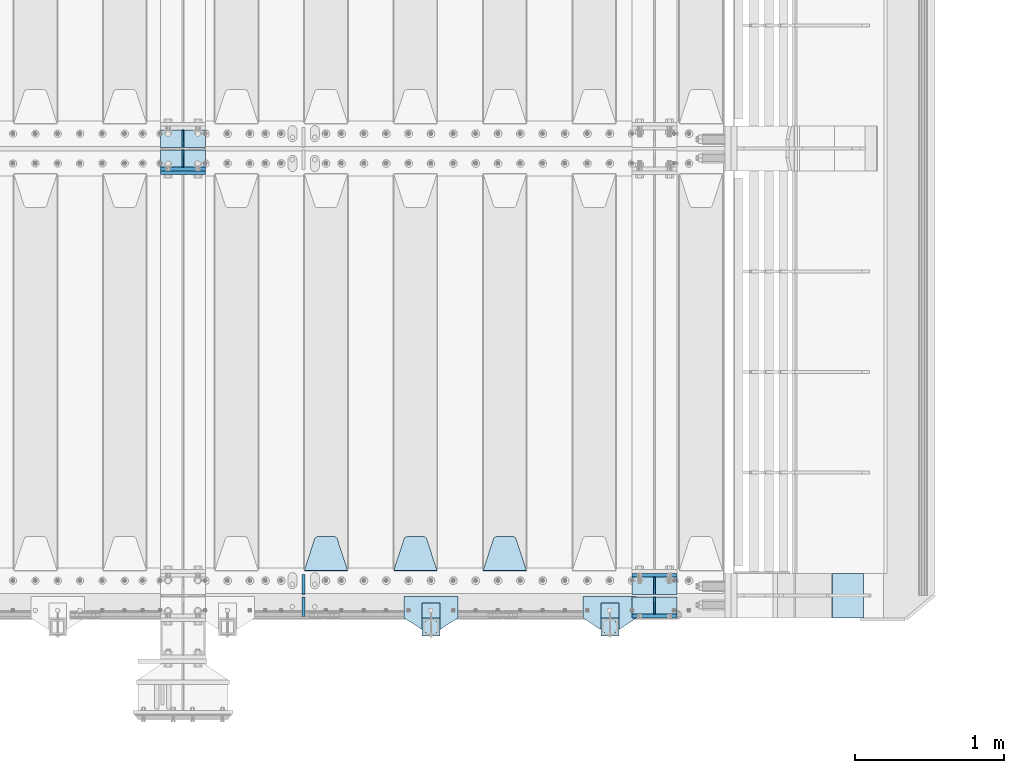
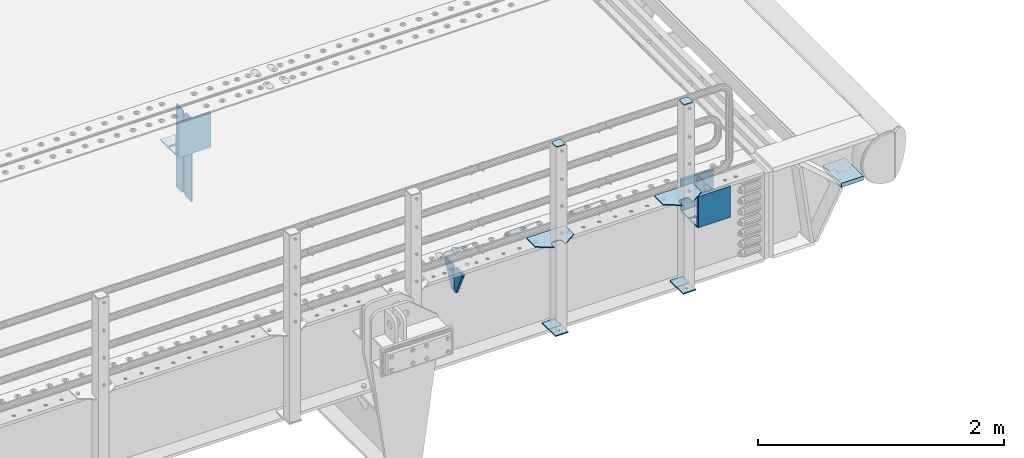
# One storey, part 184 of 219: 28 plates.
"""IFC2X3 building model written with IfcOpenShell, lengths in millimetres."""

from ifc_helpers import new_model, si_unit, frame, origin_with_axes, place, context, subcontext, project, spatial, faceted_brep, material, type_object, element, save


model = new_model("IFC2X3")

# Units and contexts
model_context = context("Model", 3, precision=1e-05, world=origin_with_axes())
body_context = subcontext(model_context, "Body", "Model", "MODEL_VIEW")
ifc_project = project(units=[si_unit("LENGTHUNIT", "METRE", prefix="MILLI"), si_unit("AREAUNIT", "SQUARE_METRE"), si_unit("VOLUMEUNIT", "CUBIC_METRE"), si_unit("MASSUNIT", "GRAM", prefix="KILO"), si_unit("TIMEUNIT", "SECOND"), si_unit("PLANEANGLEUNIT", "RADIAN"), si_unit("SOLIDANGLEUNIT", "STERADIAN"), si_unit("THERMODYNAMICTEMPERATUREUNIT", "DEGREE_CELSIUS"), si_unit("LUMINOUSINTENSITYUNIT", "LUMEN")], contexts=[model_context])

# Site, building, storey
site_placement = place(None, origin_with_axes())
site = spatial("IfcSite", under=ifc_project, at=site_placement, CompositionType="ELEMENT")
building_placement = place(site_placement, origin_with_axes())
building = spatial("IfcBuilding", under=site, at=building_placement, Name="Standard", CompositionType="ELEMENT")
storey_placement = place(building_placement, origin_with_axes())
storey = spatial("IfcBuildingStorey", under=building, at=storey_placement, Name="Undefined", CompositionType="ELEMENT", Elevation=0.0)

# Plates
ifc_material_1 = material(Name="STEEL/S355N")
plate_type_1 = type_object("IfcPlateType", PredefinedType="NOTDEFINED")
for number, where, z_axis, x_axis in (
    (1, (13405.0, 24137.5, -339.999999999995), (0.0, 0.0, 1.0), (1.0, 0.0, 0.0)),
    (2, (13405.0, 23862.5, -339.999999999995), (0.0, 0.0, 1.0), (1.0, 0.0, 0.0)),
    (3, (10240.0, 26862.5, -340.0), (0.0, 0.0, 1.0), (1.0, 0.0, 0.0)),
):
    element("IfcPlate", number, at=place(storey_placement, frame(where, z_axis=z_axis, x_axis=x_axis)), inside=storey, type_object=plate_type_1, material=ifc_material_1, context=body_context, shape_type="Brep", body=[
        faceted_brep([(0.0, -12.5, 0.0), (0.0, -12.5, 310.0), (0.0, 12.5, 310.0), (0.0, 12.5, 0.0), (300.0, -12.5, 310.0), (300.0, 12.5, 310.0), (300.0, -12.5, 0.0), (300.0, 12.5, 0.0)], [[[0, 1, 2, 3]], [[1, 4, 5, 2]], [[4, 6, 7, 5]], [[6, 0, 3, 7]], [[5, 7, 3, 2]], [[6, 4, 1, 0]]]),
    ])
plate_1_placement = place(storey_placement, frame((10240.0, 26837.5, -340.000000000044), z_axis=(0.0, 0.0, 1.0), x_axis=(1.0, 0.0, 0.0)))
element("IfcPlate", 4, at=plate_1_placement, inside=storey, type_object=plate_type_1, material=ifc_material_1, context=body_context, shape_type="Brep", body=[
    faceted_brep([(0.0, -12.5, 0.0), (9.27684595808387e-10, -12.5, 340.0), (9.27684595808387e-10, 12.5, 340.0), (0.0, 12.5, 0.0), (300.0, -12.5, 340.0), (300.0, 12.5, 340.0), (300.0, -12.5, 0.0), (300.0, 12.5, 0.0)], [[[0, 1, 2, 3]], [[1, 4, 5, 2]], [[4, 6, 7, 5]], [[6, 0, 3, 7]], [[5, 7, 3, 2]], [[6, 4, 1, 0]]]),
])
plate_type_2 = type_object("IfcPlateType", PredefinedType="NOTDEFINED")
for number, where, z_axis, x_axis in (
    (5, (13405.0, 24008.0, -342.999999999995), (0.0, 1.0, 0.0), (1.0, 0.0, 0.0)),
    (6, (13405.0, 23992.0, -342.999999999995), (0.0, -1.0, 0.0), (1.0, 0.0, 0.0)),
    (7, (10240.0, 26992.0, -343.0), (0.0, -1.0, 0.0), (1.0, 0.0, 0.0)),
    (8, (10240.0, 27008.0, -343.0), (0.0, 1.0, 0.0), (1.0, 0.0, 0.0)),
):
    element("IfcPlate", number, at=place(storey_placement, frame(where, z_axis=z_axis, x_axis=x_axis)), inside=storey, type_object=plate_type_2, material=ifc_material_1, context=body_context, shape_type="Brep", body=[
        faceted_brep([(0.0, -7.0, 0.0), (0.0, -7.0, 117.0), (0.0, 7.0, 117.0), (0.0, 7.0, 0.0), (300.0, -7.0, 117.0), (300.0, 7.0, 117.0), (300.0, -7.0, 0.0), (300.0, 7.0, 0.0)], [[[0, 1, 2, 3]], [[1, 4, 5, 2]], [[4, 6, 7, 5]], [[6, 0, 3, 7]], [[5, 7, 3, 2]], [[6, 4, 1, 0]]]),
    ])
plate_type_3 = type_object("IfcPlateType", PredefinedType="NOTDEFINED")
for number, where, z_axis, x_axis in (
    (9, (13555.0, 24008.0, -29.9999999999945), (0.0, 0.0, -1.0), (0.0, 1.0, 0.0)),
    (10, (13555.0, 23992.0, -29.9999999999945), (0.0, 0.0, -1.0), (0.0, -1.0, 0.0)),
    (11, (10390.0, 27008.0, -30.0), (0.0, 0.0, -1.0), (0.0, 1.0, 0.0)),
    (12, (10390.0, 26992.0, -30.0), (0.0, 0.0, -1.0), (0.0, -1.0, 0.0)),
):
    element("IfcPlate", number, at=place(storey_placement, frame(where, z_axis=z_axis, x_axis=x_axis)), inside=storey, type_object=plate_type_3, material=ifc_material_1, context=body_context, shape_type="Brep", body=[
        faceted_brep([(0.0, -5.0, 30.0), (0.0, -5.0, 306.0), (0.0, 5.0, 306.0), (0.0, 5.0, 30.0), (117.0, -5.0, 306.0), (117.0, 5.0, 306.0), (117.0, -5.0, 0.0), (117.0, 5.0, 0.0), (30.0, -5.0, 0.0), (30.0, 5.0, 0.0), (24.7905546699913, -5.0, 0.455767409633758), (24.7905546699913, 5.0, 0.455767409633758), (19.7393957002278, -5.0, 1.80922137642275), (19.7393957002278, 5.0, 1.80922137642275), (15.0, -5.0, 4.01923788646684), (15.0, 5.0, 4.01923788646684), (10.7163717094008, -5.0, 7.01866670643066), (10.7163717094008, 5.0, 7.01866670643066), (7.01866670643358, -5.0, 10.7163717094038), (7.01866670643358, 5.0, 10.7163717094038), (4.01923788646673, -5.0, 15.0), (4.01923788646673, 5.0, 15.0), (1.80922137642483, -5.0, 19.7393957002299), (1.80922137642483, 5.0, 19.7393957002299), (0.455767409635882, -5.0, 24.7905546699921), (0.455767409635882, 5.0, 24.7905546699921)], [[[0, 1, 2, 3]], [[1, 4, 5, 2]], [[4, 6, 7, 5]], [[6, 8, 9, 7]], [[8, 10, 11, 9]], [[10, 12, 13, 11]], [[12, 14, 15, 13]], [[14, 16, 17, 15]], [[16, 18, 19, 17]], [[18, 20, 21, 19]], [[20, 22, 23, 21]], [[22, 24, 25, 23]], [[24, 0, 3, 25]], [[5, 7, 9, 11, 13, 15, 17, 19, 21, 23, 25, 3, 2]], [[24, 22, 20, 18, 16, 14, 12, 10, 8, 6, 4, 1, 0]]]),
    ])
for number, where, z_axis, x_axis in (
    (13, (10390.0, 26992.0, -350.0), (0.0, 0.0, -1.0), (0.0, -1.0, 0.0)),
    (14, (10390.0, 27008.0, -350.0), (0.0, 0.0, -1.0), (0.0, 1.0, 0.0)),
):
    element("IfcPlate", number, at=place(storey_placement, frame(where, z_axis=z_axis, x_axis=x_axis)), inside=storey, type_object=plate_type_3, material=ifc_material_1, context=body_context, shape_type="Brep", body=[
        faceted_brep([(0.0, -5.0, 0.0), (0.0, -5.0, 480.0), (0.0, 5.0, 480.0), (0.0, 5.0, 0.0), (0.455767409635882, -5.0, 485.209445330008), (0.455767409635882, 5.0, 485.209445330008), (1.80922137642483, -5.0, 490.26060429977), (1.80922137642483, 5.0, 490.26060429977), (4.01923788646673, -5.0, 495.0), (4.01923788646673, 5.0, 495.0), (7.01866670643358, -5.0, 499.283628290596), (7.01866670643358, 5.0, 499.283628290596), (10.7163717094008, -5.0, 502.981333293569), (10.7163717094008, 5.0, 502.981333293569), (15.0, -5.0, 505.980762113533), (15.0, 5.0, 505.980762113533), (19.7393957002278, -5.0, 508.190778623577), (19.7393957002278, 5.0, 508.190778623577), (24.7905546699913, -5.0, 509.544232590366), (24.7905546699913, 5.0, 509.544232590366), (30.0, -5.0, 510.0), (30.0, 5.0, 510.0), (117.0, -5.0, 510.0), (117.0, 5.0, 510.0), (117.0, -5.0, 0.0), (117.0, 5.0, 0.0)], [[[0, 1, 2, 3]], [[1, 4, 5, 2]], [[4, 6, 7, 5]], [[6, 8, 9, 7]], [[8, 10, 11, 9]], [[10, 12, 13, 11]], [[12, 14, 15, 13]], [[14, 16, 17, 15]], [[16, 18, 19, 17]], [[18, 20, 21, 19]], [[20, 22, 23, 21]], [[22, 24, 25, 23]], [[24, 0, 3, 25]], [[5, 7, 9, 11, 13, 15, 17, 19, 21, 23, 25, 3, 2]], [[24, 22, 20, 18, 16, 14, 12, 10, 8, 6, 4, 1, 0]]]),
    ])
plate_type_4 = type_object("IfcPlateType", PredefinedType="NOTDEFINED")
plate_2_placement = place(storey_placement, frame((12695.0, 24168.232233047, -1.76776695296758), z_axis=(0.0, 0.707106781186547, -0.707106781186548), x_axis=(-1.0, 0.0, 0.0)))
element("IfcPlate", 15, at=plate_2_placement, inside=storey, type_object=plate_type_4, material=ifc_material_1, context=body_context, shape_type="Brep", body=[
    faceted_brep([(0.0, -2.5, 0.0), (69.345504679477, -2.5, 300.171731424834), (69.345504679477, 2.49999999999636, 300.171731424831), (0.0, 2.5, 0.0), (70.9274061199576, -2.50000000000364, 304.8974424154), (70.9274061199576, 2.49999999999636, 304.8974424154), (73.3818627772307, -2.50000000000364, 309.234538108532), (73.3818627772307, 2.49999999999636, 309.234538108532), (76.6187032999569, -2.50000000000364, 313.023683126106), (76.6187032999569, 2.49999999999636, 313.023683126106), (80.5190132704993, -2.50000000000364, 316.125672595372), (80.5190132704993, 2.49999999999636, 316.125672595372), (84.9395038596831, -2.50000000000364, 318.426546230476), (84.9395038596831, 2.5, 318.426546230479), (89.7177759439237, -2.50000000000364, 319.841774983277), (89.7177759439237, 2.5, 319.841774983281), (94.6782862926502, -2.50000000000364, 320.319366455078), (94.6782862926502, 2.49999999999636, 320.319366455078), (195.32171370735, -2.50000000000364, 320.319366455078), (195.32171370735, 2.49999999999636, 320.319366455078), (200.282224056076, -2.50000000000364, 319.841774983277), (200.282224056076, 2.5, 319.841774983281), (205.060496140317, -2.50000000000364, 318.426546230476), (205.060496140317, 2.49999999999636, 318.426546230476), (209.480986729501, -2.50000000000364, 316.125672595372), (209.480986729501, 2.49999999999636, 316.125672595372), (213.381296700043, -2.50000000000364, 313.023683126106), (213.381296700043, 2.49999999999272, 313.023683126106), (216.618137222769, -2.50000000000364, 309.234538108529), (216.618137222769, 2.49999999999636, 309.234538108525), (219.072593880042, -2.50000000000364, 304.8974424154), (219.072593880042, 2.49999999999636, 304.8974424154), (220.654495320523, -2.5, 300.171731424834), (220.654495320523, 2.49999999999636, 300.171731424831), (290.0, -2.50000000000364, 3.63797880709171e-12), (290.0, 2.49999999999636, 0.0)], [[[0, 1, 2, 3]], [[1, 4, 5, 2]], [[4, 6, 7, 5]], [[6, 8, 9, 7]], [[8, 10, 11, 9]], [[10, 12, 13, 11]], [[12, 14, 15, 13]], [[14, 16, 17, 15]], [[16, 18, 19, 17]], [[18, 20, 21, 19]], [[20, 22, 23, 21]], [[22, 24, 25, 23]], [[24, 26, 27, 25]], [[26, 28, 29, 27]], [[28, 30, 31, 29]], [[30, 32, 33, 31]], [[32, 34, 35, 33]], [[34, 0, 3, 35]], [[5, 7, 9, 11, 13, 15, 17, 19, 21, 23, 25, 27, 29, 31, 33, 35, 3, 2]], [[34, 32, 30, 28, 26, 24, 22, 20, 18, 16, 14, 12, 10, 8, 6, 4, 1, 0]]]),
])
plate_3_placement = place(storey_placement, frame((12095.0, 24168.232233047, -1.76776695296758), z_axis=(0.0, 0.707106781186547, -0.707106781186548), x_axis=(-1.0, 0.0, 0.0)))
element("IfcPlate", 16, at=plate_3_placement, inside=storey, type_object=plate_type_4, material=ifc_material_1, context=body_context, shape_type="Brep", body=[
    faceted_brep([(0.0, -2.5, 0.0), (69.345504679477, -2.5, 300.171731424834), (69.345504679477, 2.49999999999636, 300.171731424831), (0.0, 2.5, 0.0), (70.9274061199576, -2.50000000000364, 304.8974424154), (70.9274061199576, 2.49999999999636, 304.8974424154), (73.3818627772307, -2.50000000000364, 309.234538108532), (73.3818627772307, 2.49999999999636, 309.234538108532), (76.6187032999569, -2.50000000000364, 313.023683126106), (76.6187032999569, 2.49999999999636, 313.023683126106), (80.5190132704993, -2.50000000000364, 316.125672595372), (80.5190132704993, 2.49999999999636, 316.125672595372), (84.9395038596831, -2.50000000000364, 318.426546230476), (84.9395038596831, 2.5, 318.426546230479), (89.7177759439237, -2.50000000000364, 319.841774983277), (89.7177759439237, 2.5, 319.841774983281), (94.6782862926502, -2.50000000000364, 320.319366455078), (94.6782862926502, 2.49999999999636, 320.319366455078), (195.32171370735, -2.50000000000364, 320.319366455078), (195.32171370735, 2.49999999999636, 320.319366455078), (200.282224056076, -2.50000000000364, 319.841774983277), (200.282224056076, 2.5, 319.841774983281), (205.060496140317, -2.50000000000364, 318.426546230476), (205.060496140317, 2.49999999999636, 318.426546230476), (209.480986729501, -2.50000000000364, 316.125672595372), (209.480986729501, 2.49999999999636, 316.125672595372), (213.381296700043, -2.50000000000364, 313.023683126106), (213.381296700043, 2.49999999999272, 313.023683126106), (216.618137222769, -2.50000000000364, 309.234538108529), (216.618137222769, 2.49999999999636, 309.234538108525), (219.072593880042, -2.50000000000364, 304.8974424154), (219.072593880042, 2.49999999999636, 304.8974424154), (220.654495320523, -2.5, 300.171731424834), (220.654495320523, 2.49999999999636, 300.171731424831), (290.0, -2.50000000000364, 3.63797880709171e-12), (290.0, 2.49999999999636, 0.0)], [[[0, 1, 2, 3]], [[1, 4, 5, 2]], [[4, 6, 7, 5]], [[6, 8, 9, 7]], [[8, 10, 11, 9]], [[10, 12, 13, 11]], [[12, 14, 15, 13]], [[14, 16, 17, 15]], [[16, 18, 19, 17]], [[18, 20, 21, 19]], [[20, 22, 23, 21]], [[22, 24, 25, 23]], [[24, 26, 27, 25]], [[26, 28, 29, 27]], [[28, 30, 31, 29]], [[30, 32, 33, 31]], [[32, 34, 35, 33]], [[34, 0, 3, 35]], [[5, 7, 9, 11, 13, 15, 17, 19, 21, 23, 25, 27, 29, 31, 33, 35, 3, 2]], [[34, 32, 30, 28, 26, 24, 22, 20, 18, 16, 14, 12, 10, 8, 6, 4, 1, 0]]]),
])
plate_4_placement = place(storey_placement, frame((11495.0, 24168.232233047, -1.76776695296758), z_axis=(0.0, 0.707106781186547, -0.707106781186548), x_axis=(-1.0, 0.0, 0.0)))
element("IfcPlate", 17, at=plate_4_placement, inside=storey, type_object=plate_type_4, material=ifc_material_1, context=body_context, shape_type="Brep", body=[
    faceted_brep([(0.0, -2.5, 0.0), (69.345504679477, -2.5, 300.171731424834), (69.345504679477, 2.49999999999636, 300.171731424831), (0.0, 2.5, 0.0), (70.9274061199576, -2.50000000000364, 304.8974424154), (70.9274061199576, 2.49999999999636, 304.8974424154), (73.3818627772307, -2.50000000000364, 309.234538108532), (73.3818627772307, 2.49999999999636, 309.234538108532), (76.6187032999569, -2.50000000000364, 313.023683126106), (76.6187032999569, 2.49999999999636, 313.023683126106), (80.5190132704993, -2.50000000000364, 316.125672595372), (80.5190132704993, 2.49999999999636, 316.125672595372), (84.9395038596831, -2.50000000000364, 318.426546230476), (84.9395038596831, 2.5, 318.426546230479), (89.7177759439237, -2.50000000000364, 319.841774983277), (89.7177759439237, 2.5, 319.841774983281), (94.6782862926502, -2.50000000000364, 320.319366455078), (94.6782862926502, 2.49999999999636, 320.319366455078), (195.32171370735, -2.50000000000364, 320.319366455078), (195.32171370735, 2.49999999999636, 320.319366455078), (200.282224056076, -2.50000000000364, 319.841774983277), (200.282224056076, 2.5, 319.841774983281), (205.060496140317, -2.50000000000364, 318.426546230476), (205.060496140317, 2.49999999999636, 318.426546230476), (209.480986729501, -2.50000000000364, 316.125672595372), (209.480986729501, 2.49999999999636, 316.125672595372), (213.381296700043, -2.50000000000364, 313.023683126106), (213.381296700043, 2.49999999999272, 313.023683126106), (216.618137222769, -2.50000000000364, 309.234538108529), (216.618137222769, 2.49999999999636, 309.234538108525), (219.072593880042, -2.50000000000364, 304.8974424154), (219.072593880042, 2.49999999999636, 304.8974424154), (220.654495320523, -2.5, 300.171731424834), (220.654495320523, 2.49999999999636, 300.171731424831), (290.0, -2.50000000000364, 3.63797880709171e-12), (290.0, 2.49999999999636, 0.0)], [[[0, 1, 2, 3]], [[1, 4, 5, 2]], [[4, 6, 7, 5]], [[6, 8, 9, 7]], [[8, 10, 11, 9]], [[10, 12, 13, 11]], [[12, 14, 15, 13]], [[14, 16, 17, 15]], [[16, 18, 19, 17]], [[18, 20, 21, 19]], [[20, 22, 23, 21]], [[22, 24, 25, 23]], [[24, 26, 27, 25]], [[26, 28, 29, 27]], [[28, 30, 31, 29]], [[30, 32, 33, 31]], [[32, 34, 35, 33]], [[34, 0, 3, 35]], [[5, 7, 9, 11, 13, 15, 17, 19, 21, 23, 25, 27, 29, 31, 33, 35, 3, 2]], [[34, 32, 30, 28, 26, 24, 22, 20, 18, 16, 14, 12, 10, 8, 6, 4, 1, 0]]]),
])
plate_type_5 = type_object("IfcPlateType", PredefinedType="NOTDEFINED")
for number, where, z_axis, x_axis in (
    (18, (11200.0, 24140.0, -30.0), (0.0, 0.0, -1.0), (0.0, -1.0, 0.0)),
    (19, (11200.0, 23860.0, -30.0), (0.0, 0.0, -1.0), (0.0, 1.0, 0.0)),
):
    element("IfcPlate", number, at=place(storey_placement, frame(where, z_axis=z_axis, x_axis=x_axis)), inside=storey, type_object=plate_type_5, material=ifc_material_1, context=body_context, shape_type="Brep", body=[
        faceted_brep([(0.0, -10.0, 0.0), (0.0, -10.0, 30.0), (0.0, 10.0, 30.0), (0.0, 10.0, 0.0), (102.0, -10.0, 250.0), (102.0, 10.0, 250.0), (132.0, -10.0, 250.0), (132.0, 10.0, 250.0), (132.0, -10.0, 30.0), (132.0, 10.0, 30.0), (131.544232590368, -10.0, 24.790554669992), (131.544232590368, 10.0, 24.790554669992), (130.190778623579, -10.0, 19.7393957002299), (130.190778623579, 10.0, 19.7393957002299), (127.980762113533, -10.0, 15.0), (127.980762113533, 10.0, 15.0), (124.98133329357, -10.0, 10.7163717094038), (124.98133329357, 10.0, 10.7163717094038), (121.283628290596, -10.0, 7.01866670643062), (121.283628290596, 10.0, 7.01866670643062), (117.0, -10.0, 4.01923788646684), (117.0, 10.0, 4.01923788646684), (112.260604299769, -10.0, 1.80922137642278), (112.260604299769, 10.0, 1.80922137642278), (107.209445330009, -10.0, 0.455767409633722), (107.209445330009, 10.0, 0.455767409633722), (102.0, -10.0, 0.0), (102.0, 10.0, 0.0)], [[[0, 1, 2, 3]], [[1, 4, 5, 2]], [[4, 6, 7, 5]], [[6, 8, 9, 7]], [[8, 10, 11, 9]], [[10, 12, 13, 11]], [[12, 14, 15, 13]], [[14, 16, 17, 15]], [[16, 18, 19, 17]], [[18, 20, 21, 19]], [[20, 22, 23, 21]], [[22, 24, 25, 23]], [[24, 26, 27, 25]], [[26, 0, 3, 27]], [[5, 7, 9, 11, 13, 15, 17, 19, 21, 23, 25, 27, 3, 2]], [[26, 24, 22, 20, 18, 16, 14, 12, 10, 8, 6, 4, 1, 0]]]),
    ])
ifc_material_2 = material(Name="STEEL/S355J2")
plate_type_6 = type_object("IfcPlateType", PredefinedType="NOTDEFINED")
plate_5_placement = place(storey_placement, frame((13435.0, 23995.0, 5.00000000004911), z_axis=(0.0, -1.0, 0.0), x_axis=(-1.0, 0.0, 0.0)))
element("IfcPlate", 20, at=plate_5_placement, inside=storey, type_object=plate_type_6, material=ifc_material_2, context=body_context, shape_type="Brep", body=[
    faceted_brep([(0.0, -5.0, 0.0), (2.31396552408114e-06, -5.0, 145.0), (2.31396552408114e-06, 5.0, 145.0), (0.0, 5.0, 0.0), (130.0, -5.0, 230.0), (130.0, 5.0, 230.0), (130.0, -5.0, 180.0), (130.0, 5.0, 180.0), (130.48036798992, -5.0, 175.122741949599), (130.48036798992, 5.0, 175.122741949599), (131.903011687218, -5.0, 170.432914190875), (131.903011687218, 5.0, 170.432914190875), (134.213259692437, -5.0, 166.110744174512), (134.213259692437, 5.0, 166.110744174512), (137.322330470337, -5.0, 162.322330470335), (137.322330470337, 5.0, 162.322330470335), (141.11074417451, -5.0, 159.213259692435), (141.11074417451, 5.0, 159.213259692435), (145.432914190873, -5.0, 156.903011687216), (145.432914190873, 5.0, 156.903011687216), (150.122741949597, -5.0, 155.48036798992), (150.122741949597, 5.0, 155.48036798992), (155.0, -5.0, 155.0), (155.0, 5.0, 155.0), (205.0, -5.0, 155.0), (205.0, 5.0, 155.0), (209.877258050403, -5.0, 155.48036798992), (209.877258050403, 5.0, 155.48036798992), (214.567085809127, -5.0, 156.903011687216), (214.567085809127, 5.0, 156.903011687216), (218.88925582549, -5.0, 159.213259692435), (218.88925582549, 5.0, 159.213259692435), (222.677669529663, -5.0, 162.322330470335), (222.677669529663, 5.0, 162.322330470335), (225.786740307563, -5.0, 166.110744174512), (225.786740307563, 5.0, 166.110744174512), (228.096988312782, -5.0, 170.432914190875), (228.096988312782, 5.0, 170.432914190875), (229.51963201008, -5.0, 175.122741949599), (229.51963201008, 5.0, 175.122741949599), (230.0, -5.0, 180.0), (230.0, 5.0, 180.0), (230.0, -5.0, 230.0), (230.0, 5.0, 230.0), (360.0, -5.0, 145.0), (360.0, 5.0, 145.0), (360.0, -5.0, -7.27595761418343e-12), (360.0, 5.0, -7.27595761418343e-12)], [[[0, 1, 2, 3]], [[1, 4, 5, 2]], [[4, 6, 7, 5]], [[6, 8, 9, 7]], [[8, 10, 11, 9]], [[10, 12, 13, 11]], [[12, 14, 15, 13]], [[14, 16, 17, 15]], [[16, 18, 19, 17]], [[18, 20, 21, 19]], [[20, 22, 23, 21]], [[22, 24, 25, 23]], [[24, 26, 27, 25]], [[26, 28, 29, 27]], [[28, 30, 31, 29]], [[30, 32, 33, 31]], [[32, 34, 35, 33]], [[34, 36, 37, 35]], [[36, 38, 39, 37]], [[38, 40, 41, 39]], [[40, 42, 43, 41]], [[42, 44, 45, 43]], [[44, 46, 47, 45]], [[46, 0, 3, 47]], [[5, 7, 9, 11, 13, 15, 17, 19, 21, 23, 25, 27, 29, 31, 33, 35, 37, 39, 41, 43, 45, 47, 3, 2]], [[46, 44, 42, 40, 38, 36, 34, 32, 30, 28, 26, 24, 22, 20, 18, 16, 14, 12, 10, 8, 6, 4, 1, 0]]]),
])
plate_6_placement = place(storey_placement, frame((12235.0, 23995.0, 5.00000000004911), z_axis=(0.0, -1.0, 0.0), x_axis=(-1.0, 0.0, 0.0)))
element("IfcPlate", 21, at=plate_6_placement, inside=storey, type_object=plate_type_6, material=ifc_material_2, context=body_context, shape_type="Brep", body=[
    faceted_brep([(0.0, -5.0, 0.0), (2.31396552408114e-06, -5.0, 145.0), (2.31396552408114e-06, 5.0, 145.0), (0.0, 5.0, 0.0), (130.0, -5.0, 230.0), (130.0, 5.0, 230.0), (130.0, -5.0, 180.0), (130.0, 5.0, 180.0), (130.48036798992, -5.0, 175.122741949599), (130.48036798992, 5.0, 175.122741949599), (131.903011687218, -5.0, 170.432914190875), (131.903011687218, 5.0, 170.432914190875), (134.213259692437, -5.0, 166.110744174512), (134.213259692437, 5.0, 166.110744174512), (137.322330470337, -5.0, 162.322330470335), (137.322330470337, 5.0, 162.322330470335), (141.11074417451, -5.0, 159.213259692435), (141.11074417451, 5.0, 159.213259692435), (145.432914190873, -5.0, 156.903011687216), (145.432914190873, 5.0, 156.903011687216), (150.122741949597, -5.0, 155.48036798992), (150.122741949597, 5.0, 155.48036798992), (155.0, -5.0, 155.0), (155.0, 5.0, 155.0), (205.0, -5.0, 155.0), (205.0, 5.0, 155.0), (209.877258050403, -5.0, 155.48036798992), (209.877258050403, 5.0, 155.48036798992), (214.567085809127, -5.0, 156.903011687216), (214.567085809127, 5.0, 156.903011687216), (218.88925582549, -5.0, 159.213259692435), (218.88925582549, 5.0, 159.213259692435), (222.677669529663, -5.0, 162.322330470335), (222.677669529663, 5.0, 162.322330470335), (225.786740307563, -5.0, 166.110744174512), (225.786740307563, 5.0, 166.110744174512), (228.096988312782, -5.0, 170.432914190875), (228.096988312782, 5.0, 170.432914190875), (229.51963201008, -5.0, 175.122741949599), (229.51963201008, 5.0, 175.122741949599), (230.0, -5.0, 180.0), (230.0, 5.0, 180.0), (230.0, -5.0, 230.0), (230.0, 5.0, 230.0), (360.0, -5.0, 145.0), (360.0, 5.0, 145.0), (360.0, -5.0, -7.27595761418343e-12), (360.0, 5.0, -7.27595761418343e-12)], [[[0, 1, 2, 3]], [[1, 4, 5, 2]], [[4, 6, 7, 5]], [[6, 8, 9, 7]], [[8, 10, 11, 9]], [[10, 12, 13, 11]], [[12, 14, 15, 13]], [[14, 16, 17, 15]], [[16, 18, 19, 17]], [[18, 20, 21, 19]], [[20, 22, 23, 21]], [[22, 24, 25, 23]], [[24, 26, 27, 25]], [[26, 28, 29, 27]], [[28, 30, 31, 29]], [[30, 32, 33, 31]], [[32, 34, 35, 33]], [[34, 36, 37, 35]], [[36, 38, 39, 37]], [[38, 40, 41, 39]], [[40, 42, 43, 41]], [[42, 44, 45, 43]], [[44, 46, 47, 45]], [[46, 0, 3, 47]], [[5, 7, 9, 11, 13, 15, 17, 19, 21, 23, 25, 27, 29, 31, 33, 35, 37, 39, 41, 43, 45, 47, 3, 2]], [[46, 44, 42, 40, 38, 36, 34, 32, 30, 28, 26, 24, 22, 20, 18, 16, 14, 12, 10, 8, 6, 4, 1, 0]]]),
])
plate_type_7 = type_object("IfcPlateType", PredefinedType="NOTDEFINED")
for number, where, z_axis, x_axis in (
    (22, (13314.9999999999, 23949.9999999998, -850.000000000002), (0.0, -1.0, 0.0), (-1.0, 0.0, 0.0)),
    (23, (12114.9999999999, 23949.9999999998, -850.000000000002), (0.0, -1.0, 0.0), (-1.0, 0.0, 0.0)),
):
    element("IfcPlate", number, at=place(storey_placement, frame(where, z_axis=z_axis, x_axis=x_axis)), inside=storey, type_object=plate_type_7, material=ifc_material_2, context=body_context, shape_type="Brep", body=[
        faceted_brep([(53.6360389691836, -5.0, 176.363961030467), (53.6360389691836, 5.0, 176.363961030467), (59.9999999998618, 5.0, 178.999999999789), (59.9999999998618, -5.0, 178.999999999789), (66.3639610305399, 5.0, 176.363961030467), (66.3639610305399, -5.0, 176.363961030467), (68.9999999998618, 5.0, 169.999999999789), (68.9999999998618, -5.0, 169.999999999789), (66.3639610305399, 5.0, 163.636038969111), (66.3639610305399, -5.0, 163.636038969111), (59.9999999998618, 5.0, 160.999999999789), (59.9999999998618, -5.0, 160.999999999789), (53.6360389691836, 5.0, 163.636038969111), (53.6360389691836, -5.0, 163.636038969111), (50.9999999998618, 5.0, 169.999999999789), (50.9999999998618, -5.0, 169.999999999789), (120.0, -5.0, 0.0), (120.0, -5.0, 220.0), (0.0, -5.0, 220.0), (0.0, -5.0, 0.0), (0.0, 5.0, 0.0), (120.0, 5.0, 0.0), (120.0, 5.0, 220.0), (0.0, 5.0, 220.0)], [[[0, 1, 2, 3]], [[3, 2, 4, 5]], [[5, 4, 6, 7]], [[7, 6, 8, 9]], [[9, 8, 10, 11]], [[11, 10, 12, 13]], [[13, 12, 14, 15]], [[15, 14, 1, 0]], [[16, 17, 18, 19], [11, 13, 15, 0, 3, 5, 7, 9]], [[16, 19, 20, 21]], [[17, 16, 21, 22]], [[18, 17, 22, 23]], [[19, 18, 23, 20]], [[22, 21, 20, 23], [2, 1, 14, 12, 10, 8, 6, 4]]]),
    ])
plate_type_8 = type_object("IfcPlateType", PredefinedType="NOTDEFINED")
plate_7_placement = place(storey_placement, frame((13210.9999999999, 23833.9999999998, 1012.50000000001), z_axis=(0.0, -1.0, 0.0), x_axis=(1.0, 0.0, 0.0)))
element("IfcPlate", 24, at=plate_7_placement, inside=storey, type_object=plate_type_8, material=ifc_material_2, context=body_context, shape_type="Brep", body=[
    faceted_brep([(0.0, -2.5, 19.0), (0.0, -2.5, 69.0), (0.0, 2.5, 69.0), (0.0, 2.5, 19.0), (0.476369668545885, -2.5, 73.2278977451715), (0.476369668545885, 2.5, 73.2278977451715), (1.88159150985484, -2.5, 77.2437910432345), (1.88159150985484, 2.5, 77.2437910432345), (4.14520183310742, -2.5, 80.8463062353185), (4.14520183310742, 2.5, 80.8463062353185), (7.15369376468334, -2.5, 83.8547981668889), (7.15369376468334, 2.5, 83.8547981668889), (10.7562089567673, -2.5, 86.118408490147), (10.7562089567673, 2.5, 86.118408490147), (14.7721022548303, -2.5, 87.5236303314523), (14.7721022548303, 2.5, 87.5236303314523), (19.0, -2.5, 88.0), (19.0, 2.5, 88.0), (69.0, -2.5, 88.0), (69.0, 2.5, 88.0), (73.2278977451697, -2.5, 87.5236303314523), (73.2278977451697, 2.5, 87.5236303314523), (77.2437910432327, -2.5, 86.118408490147), (77.2437910432327, 2.5, 86.118408490147), (80.8463062353167, -2.5, 83.8547981668889), (80.8463062353167, 2.5, 83.8547981668889), (83.8547981668926, -2.5, 80.8463062353185), (83.8547981668926, 2.5, 80.8463062353185), (86.1184084901452, -2.5, 77.2437910432345), (86.1184084901452, 2.5, 77.2437910432345), (87.5236303314541, -2.5, 73.2278977451715), (87.5236303314541, 2.5, 73.2278977451715), (88.0, -2.5, 69.0), (88.0, 2.5, 69.0), (88.0, -2.5, 19.0), (88.0, 2.5, 19.0), (87.5236303314541, -2.5, 14.7721022548285), (87.5236303314541, 2.5, 14.7721022548285), (86.1184084901452, -2.5, 10.7562089567655), (86.1184084901452, 2.5, 10.7562089567655), (83.8547981668926, -2.5, 7.15369376468152), (83.8547981668926, 2.5, 7.15369376468152), (80.8463062353167, -2.5, 4.14520183311106), (80.8463062353167, 2.5, 4.14520183311106), (77.2437910432345, -2.5, 1.88159150985302), (77.2437910432345, 2.5, 1.88159150985302), (73.2278977451697, -2.5, 0.476369668547704), (73.2278977451697, 2.5, 0.476369668547704), (69.0, -2.5, 0.0), (69.0, 2.5, 0.0), (19.0, -2.5, 0.0), (19.0, 2.5, 0.0), (14.7721022548303, -2.5, 0.476369668547704), (14.7721022548303, 2.5, 0.476369668547704), (10.7562089567673, -2.5, 1.88159150985302), (10.7562089567673, 2.5, 1.88159150985302), (7.15369376468334, -2.5, 4.14520183311106), (7.15369376468334, 2.5, 4.14520183311106), (4.14520183310742, -2.5, 7.15369376468152), (4.14520183310742, 2.5, 7.15369376468152), (1.88159150985484, -2.5, 10.7562089567655), (1.88159150985484, 2.5, 10.7562089567655), (0.476369668545885, -2.5, 14.7721022548285), (0.476369668545885, 2.5, 14.7721022548285)], [[[0, 1, 2, 3]], [[1, 4, 5, 2]], [[4, 6, 7, 5]], [[6, 8, 9, 7]], [[8, 10, 11, 9]], [[10, 12, 13, 11]], [[12, 14, 15, 13]], [[14, 16, 17, 15]], [[16, 18, 19, 17]], [[18, 20, 21, 19]], [[20, 22, 23, 21]], [[22, 24, 25, 23]], [[24, 26, 27, 25]], [[26, 28, 29, 27]], [[28, 30, 31, 29]], [[30, 32, 33, 31]], [[32, 34, 35, 33]], [[34, 36, 37, 35]], [[36, 38, 39, 37]], [[38, 40, 41, 39]], [[40, 42, 43, 41]], [[42, 44, 45, 43]], [[44, 46, 47, 45]], [[46, 48, 49, 47]], [[48, 50, 51, 49]], [[50, 52, 53, 51]], [[52, 54, 55, 53]], [[54, 56, 57, 55]], [[56, 58, 59, 57]], [[58, 60, 61, 59]], [[60, 62, 63, 61]], [[62, 0, 3, 63]], [[5, 7, 9, 11, 13, 15, 17, 19, 21, 23, 25, 27, 29, 31, 33, 35, 37, 39, 41, 43, 45, 47, 49, 51, 53, 55, 57, 59, 61, 63, 3, 2]], [[62, 60, 58, 56, 54, 52, 50, 48, 46, 44, 42, 40, 38, 36, 34, 32, 30, 28, 26, 24, 22, 20, 18, 16, 14, 12, 10, 8, 6, 4, 1, 0]]]),
])
plate_8_placement = place(storey_placement, frame((12010.9999999999, 23833.9999999998, 1012.50000000001), z_axis=(0.0, -1.0, 0.0), x_axis=(1.0, 0.0, 0.0)))
element("IfcPlate", 25, at=plate_8_placement, inside=storey, type_object=plate_type_8, material=ifc_material_2, context=body_context, shape_type="Brep", body=[
    faceted_brep([(0.0, -2.5, 19.0), (0.0, -2.5, 69.0), (0.0, 2.5, 69.0), (0.0, 2.5, 19.0), (0.476369668545885, -2.5, 73.2278977451715), (0.476369668545885, 2.5, 73.2278977451715), (1.88159150985484, -2.5, 77.2437910432345), (1.88159150985484, 2.5, 77.2437910432345), (4.14520183310742, -2.5, 80.8463062353185), (4.14520183310742, 2.5, 80.8463062353185), (7.15369376468334, -2.5, 83.8547981668889), (7.15369376468334, 2.5, 83.8547981668889), (10.7562089567673, -2.5, 86.118408490147), (10.7562089567673, 2.5, 86.118408490147), (14.7721022548303, -2.5, 87.5236303314523), (14.7721022548303, 2.5, 87.5236303314523), (19.0, -2.5, 88.0), (19.0, 2.5, 88.0), (69.0, -2.5, 88.0), (69.0, 2.5, 88.0), (73.2278977451697, -2.5, 87.5236303314523), (73.2278977451697, 2.5, 87.5236303314523), (77.2437910432327, -2.5, 86.118408490147), (77.2437910432327, 2.5, 86.118408490147), (80.8463062353167, -2.5, 83.8547981668889), (80.8463062353167, 2.5, 83.8547981668889), (83.8547981668926, -2.5, 80.8463062353185), (83.8547981668926, 2.5, 80.8463062353185), (86.1184084901452, -2.5, 77.2437910432345), (86.1184084901452, 2.5, 77.2437910432345), (87.5236303314541, -2.5, 73.2278977451715), (87.5236303314541, 2.5, 73.2278977451715), (88.0, -2.5, 69.0), (88.0, 2.5, 69.0), (88.0, -2.5, 19.0), (88.0, 2.5, 19.0), (87.5236303314541, -2.5, 14.7721022548285), (87.5236303314541, 2.5, 14.7721022548285), (86.1184084901452, -2.5, 10.7562089567655), (86.1184084901452, 2.5, 10.7562089567655), (83.8547981668926, -2.5, 7.15369376468152), (83.8547981668926, 2.5, 7.15369376468152), (80.8463062353167, -2.5, 4.14520183311106), (80.8463062353167, 2.5, 4.14520183311106), (77.2437910432345, -2.5, 1.88159150985302), (77.2437910432345, 2.5, 1.88159150985302), (73.2278977451697, -2.5, 0.476369668547704), (73.2278977451697, 2.5, 0.476369668547704), (69.0, -2.5, 0.0), (69.0, 2.5, 0.0), (19.0, -2.5, 0.0), (19.0, 2.5, 0.0), (14.7721022548303, -2.5, 0.476369668547704), (14.7721022548303, 2.5, 0.476369668547704), (10.7562089567673, -2.5, 1.88159150985302), (10.7562089567673, 2.5, 1.88159150985302), (7.15369376468334, -2.5, 4.14520183311106), (7.15369376468334, 2.5, 4.14520183311106), (4.14520183310742, -2.5, 7.15369376468152), (4.14520183310742, 2.5, 7.15369376468152), (1.88159150985484, -2.5, 10.7562089567655), (1.88159150985484, 2.5, 10.7562089567655), (0.476369668545885, -2.5, 14.7721022548285), (0.476369668545885, 2.5, 14.7721022548285)], [[[0, 1, 2, 3]], [[1, 4, 5, 2]], [[4, 6, 7, 5]], [[6, 8, 9, 7]], [[8, 10, 11, 9]], [[10, 12, 13, 11]], [[12, 14, 15, 13]], [[14, 16, 17, 15]], [[16, 18, 19, 17]], [[18, 20, 21, 19]], [[20, 22, 23, 21]], [[22, 24, 25, 23]], [[24, 26, 27, 25]], [[26, 28, 29, 27]], [[28, 30, 31, 29]], [[30, 32, 33, 31]], [[32, 34, 35, 33]], [[34, 36, 37, 35]], [[36, 38, 39, 37]], [[38, 40, 41, 39]], [[40, 42, 43, 41]], [[42, 44, 45, 43]], [[44, 46, 47, 45]], [[46, 48, 49, 47]], [[48, 50, 51, 49]], [[50, 52, 53, 51]], [[52, 54, 55, 53]], [[54, 56, 57, 55]], [[56, 58, 59, 57]], [[58, 60, 61, 59]], [[60, 62, 63, 61]], [[62, 0, 3, 63]], [[5, 7, 9, 11, 13, 15, 17, 19, 21, 23, 25, 27, 29, 31, 33, 35, 37, 39, 41, 43, 45, 47, 49, 51, 53, 55, 57, 59, 61, 63, 3, 2]], [[62, 60, 58, 56, 54, 52, 50, 48, 46, 44, 42, 40, 38, 36, 34, 32, 30, 28, 26, 24, 22, 20, 18, 16, 14, 12, 10, 8, 6, 4, 1, 0]]]),
])
plate_type_9 = type_object("IfcPlateType", PredefinedType="NOTDEFINED")
for number, where, z_axis, x_axis in (
    (26, (13314.9999999999, 23949.9999999998, -857.500000000002), (0.0, -1.0, 0.0), (-1.0, 0.0, 0.0)),
    (27, (12114.9999999999, 23949.9999999998, -857.500000000002), (0.0, -1.0, 0.0), (-1.0, 0.0, 0.0)),
):
    element("IfcPlate", number, at=place(storey_placement, frame(where, z_axis=z_axis, x_axis=x_axis)), inside=storey, type_object=plate_type_9, material=ifc_material_2, context=body_context, shape_type="Brep", body=[
        faceted_brep([(0.0, -2.5, 0.0), (0.0, -2.5, 100.0), (0.0, 2.5, 100.0), (0.0, 2.5, 0.0), (120.0, -2.5, 100.0), (120.0, 2.5, 100.0), (120.0, -2.5, 0.0), (120.0, 2.5, 0.0)], [[[0, 1, 2, 3]], [[1, 4, 5, 2]], [[4, 6, 7, 5]], [[6, 0, 3, 7]], [[5, 7, 3, 2]], [[6, 4, 1, 0]]]),
    ])
plate_type_10 = type_object("IfcPlateType", PredefinedType="NOTDEFINED")
plate_9_placement = place(storey_placement, frame((14748.9988298898, 23849.9999999992, -387.999999998825), z_axis=(1.0, 0.0, 0.0), x_axis=(0.0, 1.0, 0.0)))
element("IfcPlate", 28, at=plate_9_placement, inside=storey, type_object=plate_type_10, material=ifc_material_1, context=body_context, shape_type="Brep", body=[
    faceted_brep([(0.0, -20.0, 0.0), (3.31056071445346e-10, -20.0, 208.0), (3.31056071445346e-10, 20.0, 208.0), (0.0, 20.0, 0.0), (300.0, -20.0, 208.0), (300.0, 20.0, 208.0), (300.0, -20.0, -1.81898940354586e-12), (300.0, 20.0, -1.81898940354586e-12)], [[[0, 1, 2, 3]], [[1, 4, 5, 2]], [[4, 6, 7, 5]], [[6, 0, 3, 7]], [[5, 7, 3, 2]], [[6, 4, 1, 0]]]),
])

save(model, "model.ifc")
